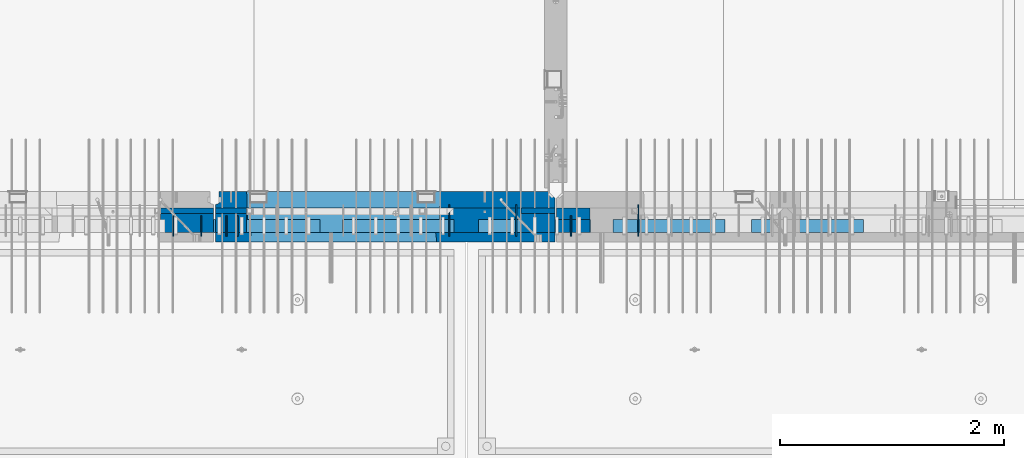
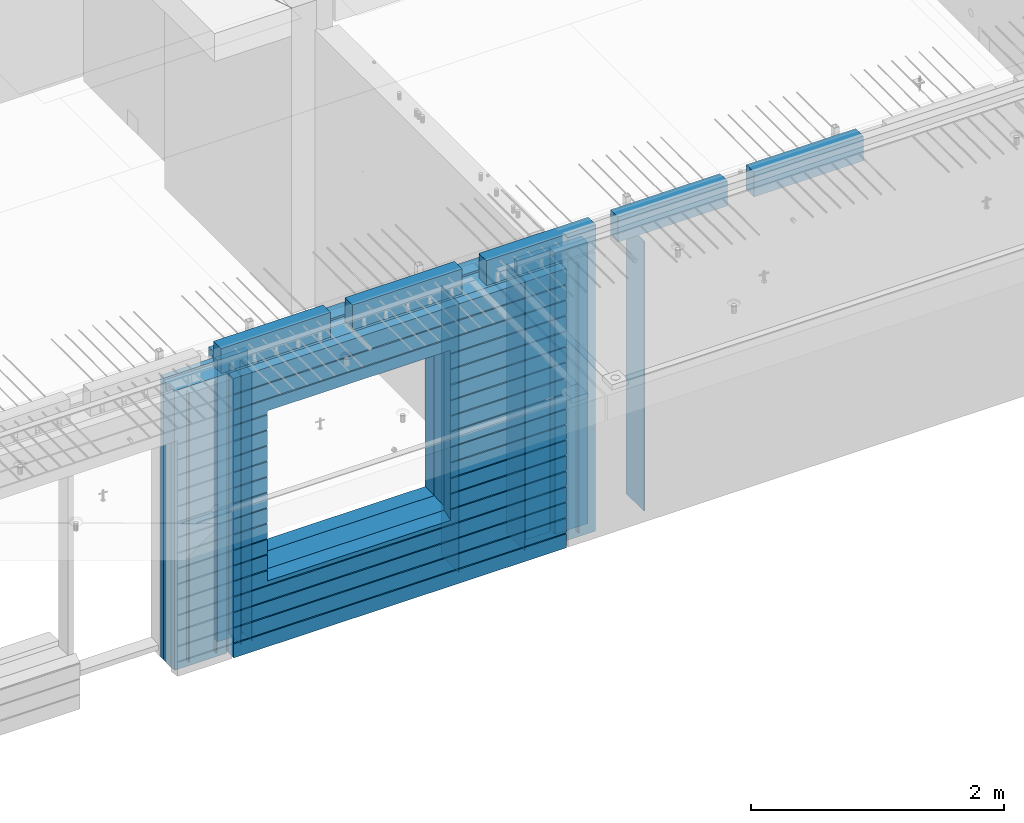
# One storey, part 232 of 349: 24 walls, 10 elements without a shape of their own.
"""IFC2X3 building model written with IfcOpenShell, lengths in millimetres."""

import ifcopenshell
import ifcopenshell.guid

model = None  # the IFC model being written
_history = None  # IfcOwnerHistory: only IFC2X3 demands one
_inside = {}  # id of a spatial element -> (the spatial element, [elements in it])
_under = {}  # id of a project, library or spatial element -> (it, [spatial elements below it])
_declared = {}  # id of a project -> (the project, [libraries it declares])
_typed = {}  # id of a type object -> (the type object, [elements of that type])
_made_of = {}  # id of a material, layer set ... -> (it, [elements and type objects made of it])


def new_model(schema):
    """Start an empty IFC model of exactly this schema.

    Asked for "IFC4X3", IfcOpenShell would pick the latest addendum, in which some entities
    have other attributes; the version numbers below select the first issue.
    IFC2X3 requires an IfcOwnerHistory on every rooted entity: one is made here for all.
    """
    global model, _history
    if schema == "IFC4X3":
        model = ifcopenshell.file(schema_version=(4, 3, 0, 0))
    else:
        model = ifcopenshell.file(schema=schema)
    _inside.clear()
    _under.clear()
    _declared.clear()
    _typed.clear()
    _made_of.clear()
    _history = None
    if model.schema == "IFC2X3":
        org = make("IfcOrganization", Name="unknown")
        user = make(
            "IfcPersonAndOrganization",
            ThePerson=make("IfcPerson", FamilyName="unknown"),
            TheOrganization=org,
        )
        app = make(
            "IfcApplication",
            ApplicationDeveloper=org,
            Version="unknown",
            ApplicationFullName="unknown",
            ApplicationIdentifier="unknown",
        )
        _history = make(
            "IfcOwnerHistory",
            OwningUser=user,
            OwningApplication=app,
            ChangeAction="ADDED",
            CreationDate=0,
        )
    return model


def make(cls, **values):
    """One entity of the class cls with the attributes given. An attribute that is None is left unset."""
    return model.create_entity(
        cls, **{name: value for name, value in values.items() if value is not None}
    )


def rooted(cls, **values):
    """An entity with a GlobalId (a new one), such as an element, a storey or a relation."""
    return make(cls, GlobalId=ifcopenshell.guid.new(), OwnerHistory=_history, **values)


def si_unit(unit_type, name, prefix=None):
    """IfcSIUnit, for example si_unit("LENGTHUNIT", "METRE", prefix="MILLI")."""
    return make("IfcSIUnit", UnitType=unit_type, Prefix=prefix, Name=name)


def assignment(units):
    """IfcUnitAssignment: the units of a project."""
    return None if units is None else make("IfcUnitAssignment", Units=units)


def point(xyz):
    """IfcCartesianPoint."""
    return None if xyz is None else make("IfcCartesianPoint", Coordinates=xyz)


def direction(xyz):
    """IfcDirection."""
    return None if xyz is None else make("IfcDirection", DirectionRatios=xyz)


def frame(location, z_axis=None, x_axis=None):
    """IfcAxis2Placement3D, a coordinate frame: its origin and axes. An axis left out is left unset."""
    return make(
        "IfcAxis2Placement3D",
        Location=point(location),
        Axis=direction(z_axis),
        RefDirection=direction(x_axis),
    )


def origin_with_axes():
    """The frame at (0, 0, 0) with the z axis (0, 0, 1) and the x axis (1, 0, 0) written out."""
    return frame((0.0, 0.0, 0.0), z_axis=(0.0, 0.0, 1.0), x_axis=(1.0, 0.0, 0.0))


def place(relative_to, where):
    """IfcLocalPlacement: puts the frame where relative to a parent placement (None: the world)."""
    return make(
        "IfcLocalPlacement", PlacementRelTo=relative_to, RelativePlacement=where
    )


def context(
    kind, dimensions, precision=None, world=None, true_north=None, identifier=None
):
    """IfcGeometricRepresentationContext, for example the 3D "Model" context."""
    return make(
        "IfcGeometricRepresentationContext",
        ContextIdentifier=identifier,
        ContextType=kind,
        CoordinateSpaceDimension=dimensions,
        Precision=precision,
        WorldCoordinateSystem=world,
        TrueNorth=true_north,
    )


def subcontext(parent, identifier, kind, view, scale=None):
    """IfcGeometricRepresentationSubContext, for example "Body" below "Model"."""
    return make(
        "IfcGeometricRepresentationSubContext",
        ContextIdentifier=identifier,
        ContextType=kind,
        ParentContext=parent,
        TargetScale=scale,
        TargetView=view,
    )


def project(units=None, contexts=None):
    """IfcProject with its units and contexts."""
    return rooted(
        "IfcProject",
        Name="project",
        RepresentationContexts=contexts,
        UnitsInContext=assignment(units),
    )


def spatial(cls, under=None, at=None, **own):
    """A site, building, storey or space (cls), placed at a placement, below another one or the project."""
    s = rooted(cls, ObjectPlacement=at, **own)
    if under is not None:
        _under.setdefault(under.id(), (under, []))[1].append(s)
    return s


def faces_of(points, faces, orient=None, outer=None):
    """IfcFace entities. A face is a list of loops; a loop is a list of indices into points, from 0.

    orient and outer hold one flag for each loop. By default every Orientation is true, the
    first loop of a face is its IfcFaceOuterBound and the others are IfcFaceBound.
    """
    made = []
    for i, loops in enumerate(faces):
        bounds = []
        for j, loop in enumerate(loops):
            is_outer = j == 0 if outer is None else outer[i][j]
            bounds.append(
                make(
                    "IfcFaceOuterBound" if is_outer else "IfcFaceBound",
                    Bound=make("IfcPolyLoop", Polygon=[points[k] for k in loop]),
                    Orientation=True if orient is None else orient[i][j],
                )
            )
        made.append(make("IfcFace", Bounds=bounds))
    return made


def faceted_brep(points, faces, orient=None, outer=None, voids=None):
    """IfcFacetedBrep: a solid bounded by flat faces; with voids (closed shells), ...WithVoids."""
    shared = [point(p) for p in points]
    hull = make("IfcClosedShell", CfsFaces=faces_of(shared, faces, orient, outer))
    if voids is None:
        return make("IfcFacetedBrep", Outer=hull)
    return make(
        "IfcFacetedBrepWithVoids",
        Outer=hull,
        Voids=[
            make(cls, CfsFaces=faces_of(shared, fs, o, b)) for cls, fs, o, b in voids
        ],
    )


def shape(context_of_items, identifier, shape_type, items):
    """IfcShapeRepresentation: the items that make up one representation, for example the "Body"."""
    return make(
        "IfcShapeRepresentation",
        ContextOfItems=context_of_items,
        RepresentationIdentifier=identifier,
        RepresentationType=shape_type,
        Items=items,
    )


def material(Name=None, Category=None):
    """IfcMaterial."""
    return make("IfcMaterial", Name=Name, Category=Category)


def made_of(thing, what):
    """Note that an element or type object is made of a material, layer set ...; save() writes the relation."""
    if what is not None:
        _made_of.setdefault(what.id(), (what, []))[1].append(thing)
    return thing


def type_object(cls, material=None, **own):
    """A type object (cls), such as IfcWallType, which elements share."""
    return made_of(rooted(cls, **own), material)


def element(
    cls,
    number,
    at=None,
    inside=None,
    cuts=None,
    type_object=None,
    material=None,
    context=None,
    identifier="Body",
    shape_type=None,
    held_by="IfcProductDefinitionShape",
    body=None,
    shapes=None,
    **own,
):
    """One element of the class cls, such as IfcWall. Its Tag is "e" and its number.

    at: its placement. inside: the storey or other place that contains it. cuts: it is an
    opening in that element (IfcRelVoidsElement). A single representation is given by context,
    identifier, shape_type and body (its items); several are given by shapes. held_by: the class
    of the entity that holds the representations. save() writes the other relations.
    """
    e = rooted(cls, Tag="e%d" % number, ObjectPlacement=at, **own)
    if body is not None:
        shapes = [shape(context, identifier, shape_type, body)]
    if shapes is not None:
        e.Representation = make(held_by, Representations=shapes)
    if inside is not None:
        _inside.setdefault(inside.id(), (inside, []))[1].append(e)
    if cuts is not None:
        rooted(
            "IfcRelVoidsElement", RelatingBuildingElement=cuts, RelatedOpeningElement=e
        )
    if type_object is not None:
        _typed.setdefault(type_object.id(), (type_object, []))[1].append(e)
    return made_of(e, material)


def aggregate(whole, parts):
    """IfcRelAggregates: a whole, such as a stair, and the parts it consists of."""
    return rooted("IfcRelAggregates", RelatingObject=whole, RelatedObjects=parts)


def save(model, path):
    """Write the relations noted so far, then the file.

    IfcRelAggregates (storeys below a building ...), IfcRelContainedInSpatialStructure (elements
    in a storey), IfcRelDefinesByType, IfcRelAssociatesMaterial and IfcRelDeclares: one each for
    every whole, place, type object, material and project.
    """
    for whole, parts in _under.values():
        aggregate(whole, parts)
    for where, things in _inside.values():
        rooted(
            "IfcRelContainedInSpatialStructure",
            RelatedElements=things,
            RelatingStructure=where,
        )
    for kind, things in _typed.values():
        rooted("IfcRelDefinesByType", RelatedObjects=things, RelatingType=kind)
    for what, things in _made_of.values():
        rooted("IfcRelAssociatesMaterial", RelatedObjects=things, RelatingMaterial=what)
    for by, libraries in _declared.values():
        rooted("IfcRelDeclares", RelatingContext=by, RelatedDefinitions=libraries)
    model.write(path)


model = new_model("IFC2X3")

# Units and contexts
model_context = context("Model", 3, precision=1e-05, world=origin_with_axes())
body_context = subcontext(model_context, "Body", "Model", "MODEL_VIEW")
ifc_project = project(units=[si_unit("LENGTHUNIT", "METRE", prefix="MILLI"), si_unit("AREAUNIT", "SQUARE_METRE"), si_unit("VOLUMEUNIT", "CUBIC_METRE"), si_unit("MASSUNIT", "GRAM", prefix="KILO"), si_unit("TIMEUNIT", "SECOND"), si_unit("PLANEANGLEUNIT", "RADIAN"), si_unit("SOLIDANGLEUNIT", "STERADIAN"), si_unit("THERMODYNAMICTEMPERATUREUNIT", "DEGREE_CELSIUS"), si_unit("LUMINOUSINTENSITYUNIT", "LUMEN")], contexts=[model_context])

# Site, building, storey
site_placement = place(None, origin_with_axes())
site = spatial("IfcSite", under=ifc_project, at=site_placement, CompositionType="ELEMENT")
building_placement = place(site_placement, origin_with_axes())
building = spatial("IfcBuilding", under=site, at=building_placement, CompositionType="ELEMENT")
storey_placement = place(building_placement, origin_with_axes())
storey = spatial("IfcBuildingStorey", under=building, at=storey_placement, Name="4", CompositionType="ELEMENT", Elevation=0.0)

# Assembly, walls
assembly_1_placement = place(storey_placement, origin_with_axes())
assembly_1 = element("IfcElementAssembly", 1, at=assembly_1_placement, inside=storey, AssemblyPlace="NOTDEFINED", PredefinedType="REINFORCEMENT_UNIT")
ifc_material_1 = material(Name="Undefined")
wall_type_1 = type_object("IfcWallType", PredefinedType="NOTDEFINED")
wall_1_placement = place(assembly_1_placement, frame((25665.0, 7780.0, 92115.0), z_axis=(0.0, 0.0, 1.0), x_axis=(0.0, -1.0, 0.0)))
wall_1 = element("IfcWall", 2, at=wall_1_placement, type_object=wall_type_1, material=ifc_material_1, Name="(PD)", context=body_context, shape_type="Brep", body=[
    faceted_brep([(0.0, 5.0, -1300.0), (0.0, 5.0, 1300.0), (180.0, 5.0, 1300.0), (180.0, 5.0, -1300.0), (0.0, -5.0, 1300.0), (180.0, -5.0, 1300.0), (0.0, -5.0, -1300.0), (180.0, -5.0, -1300.0)], [[[0, 1, 2, 3]], [[1, 4, 5, 2]], [[4, 6, 7, 5]], [[6, 0, 3, 7]], [[5, 7, 3, 2]], [[6, 4, 1, 0]]]),
])
wall_2_placement = place(assembly_1_placement, frame((25765.0, 7780.0, 92115.0), z_axis=(0.0, 0.0, 1.0), x_axis=(0.0, -1.0, 0.0)))
wall_2 = element("IfcWall", 3, at=wall_2_placement, type_object=wall_type_1, material=ifc_material_1, Name="(PD)", context=body_context, shape_type="Brep", body=[
    faceted_brep([(0.0, 5.0, -1300.0), (0.0, 5.0, 1300.0), (180.0, 5.0, 1300.0), (180.0, 5.0, -1300.0), (0.0, -5.0, 1300.0), (180.0, -5.0, 1300.0), (0.0, -5.0, -1300.0), (180.0, -5.0, -1300.0)], [[[0, 1, 2, 3]], [[1, 4, 5, 2]], [[4, 6, 7, 5]], [[6, 0, 3, 7]], [[5, 7, 3, 2]], [[6, 4, 1, 0]]]),
])
wall_3_placement = place(assembly_1_placement, frame((28255.0, 7880.0, 92115.0), z_axis=(0.0, 0.0, 1.0), x_axis=(0.0, -1.0, 0.0)))
wall_3 = element("IfcWall", 4, at=wall_3_placement, type_object=wall_type_1, material=ifc_material_1, Name="(PD)", context=body_context, shape_type="Brep", body=[
    faceted_brep([(0.0, 5.0, -1300.0), (0.0, 5.0, 1300.0), (280.0, 5.0, 1300.0), (280.0, 5.0, -1300.0), (0.0, -5.0, 1300.0), (280.0, -5.0, 1300.0), (0.0, -5.0, -1300.0), (280.0, -5.0, -1300.0)], [[[0, 1, 2, 3]], [[1, 4, 5, 2]], [[4, 6, 7, 5]], [[6, 0, 3, 7]], [[5, 7, 3, 2]], [[6, 4, 1, 0]]]),
])

assembly_2_placement = place(storey_placement, origin_with_axes())
assembly_2 = element("IfcElementAssembly", 5, at=assembly_2_placement, inside=storey, AssemblyPlace="NOTDEFINED", PredefinedType="REINFORCEMENT_UNIT")
wall_4_placement = place(assembly_2_placement, frame((28745.0021834468, 7780.0, 92115.0), z_axis=(0.0, 0.0, 1.0), x_axis=(0.0, -1.0, 0.0)))
wall_4 = element("IfcWall", 6, at=wall_4_placement, type_object=wall_type_1, material=ifc_material_1, Name="(PD)", context=body_context, shape_type="Brep", body=[
    faceted_brep([(0.0, 5.0, -1300.0), (0.0, 5.0, 1300.0), (180.0, 5.0, 1300.0), (180.0, 5.0, -1300.0), (0.0, -5.0, 1300.0), (180.0, -5.0, 1300.0), (0.0, -5.0, -1300.0), (180.0, -5.0, -1300.0)], [[[0, 1, 2, 3]], [[1, 4, 5, 2]], [[4, 6, 7, 5]], [[6, 0, 3, 7]], [[5, 7, 3, 2]], [[6, 4, 1, 0]]]),
])
wall_5_placement = place(assembly_2_placement, frame((29345.0021834468, 7880.0, 92115.0), z_axis=(0.0, 0.0, 1.0), x_axis=(0.0, -1.0, 0.0)))
wall_5 = element("IfcWall", 7, at=wall_5_placement, type_object=wall_type_1, material=ifc_material_1, Name="(PD)", context=body_context, shape_type="Brep", body=[
    faceted_brep([(0.0, 5.0, -1300.0), (0.0, 5.0, 1300.0), (280.0, 5.0, 1300.0), (280.0, 5.0, -1300.0), (0.0, -5.0, 1300.0), (280.0, -5.0, 1300.0), (0.0, -5.0, -1300.0), (280.0, -5.0, -1300.0)], [[[0, 1, 2, 3]], [[1, 4, 5, 2]], [[4, 6, 7, 5]], [[6, 0, 3, 7]], [[5, 7, 3, 2]], [[6, 4, 1, 0]]]),
])

assembly_3_placement = place(storey_placement, origin_with_axes())
assembly_3 = element("IfcElementAssembly", 8, at=assembly_3_placement, inside=storey, AssemblyPlace="NOTDEFINED", PredefinedType="REINFORCEMENT_UNIT")
wall_6_placement = place(assembly_3_placement, frame((25190.0, 7780.0, 92115.0), z_axis=(0.0, 0.0, 1.0), x_axis=(0.0, -1.0, 0.0)))
wall_6 = element("IfcWall", 9, at=wall_6_placement, type_object=wall_type_1, material=ifc_material_1, Name="(PD)", context=body_context, shape_type="Brep", body=[
    faceted_brep([(0.0, 5.0, -1300.0), (0.0, 5.0, 1300.0), (180.0, 5.0, 1300.0), (180.0, 5.0, -1300.0), (0.0, -5.0, 1300.0), (180.0, -5.0, 1300.0), (0.0, -5.0, -1300.0), (180.0, -5.0, -1300.0)], [[[0, 1, 2, 3]], [[1, 4, 5, 2]], [[4, 6, 7, 5]], [[6, 0, 3, 7]], [[5, 7, 3, 2]], [[6, 4, 1, 0]]]),
])
wall_7_placement = place(assembly_3_placement, frame((25440.0, 7780.0, 92115.0), z_axis=(0.0, 0.0, 1.0), x_axis=(0.0, -1.0, 0.0)))
wall_7 = element("IfcWall", 10, at=wall_7_placement, type_object=wall_type_1, material=ifc_material_1, Name="(PD)", context=body_context, shape_type="Brep", body=[
    faceted_brep([(0.0, 5.0, -1300.0), (0.0, 5.0, 1300.0), (180.0, 5.0, 1300.0), (180.0, 5.0, -1300.0), (0.0, -5.0, 1300.0), (180.0, -5.0, 1300.0), (0.0, -5.0, -1300.0), (180.0, -5.0, -1300.0)], [[[0, 1, 2, 3]], [[1, 4, 5, 2]], [[4, 6, 7, 5]], [[6, 0, 3, 7]], [[5, 7, 3, 2]], [[6, 4, 1, 0]]]),
])

# Wall
wall_8_placement = place(assembly_1_placement, frame((27655.0, 7880.0, 92115.0), z_axis=(0.0, 0.0, 1.0), x_axis=(0.0, -1.0, 0.0)))
wall_8 = element("IfcWall", 11, at=wall_8_placement, type_object=wall_type_1, material=ifc_material_1, Name="(PD)", context=body_context, shape_type="Brep", body=[
    faceted_brep([(0.0, 5.0, -1300.0), (0.0, 5.0, 1300.0), (280.0, 5.0, 1300.0), (280.0, 5.0, -1300.0), (0.0, -5.0, 1300.0), (280.0, -5.0, 1300.0), (0.0, -5.0, -1300.0), (280.0, -5.0, -1300.0)], [[[0, 1, 2, 3]], [[1, 4, 5, 2]], [[4, 6, 7, 5]], [[6, 0, 3, 7]], [[5, 7, 3, 2]], [[6, 4, 1, 0]]]),
])

# Assemblies, walls
assembly_4_placement = place(storey_placement, origin_with_axes())
assembly_4 = element("IfcElementAssembly", 12, at=assembly_4_placement, inside=storey, AssemblyPlace="NOTDEFINED", PredefinedType="REINFORCEMENT_UNIT")
assembly_5_placement = place(assembly_4_placement, origin_with_axes())
assembly_5 = element("IfcElementAssembly", 13, at=assembly_5_placement, Name="Steel Assembly", AssemblyPlace="NOTDEFINED", PredefinedType="NOTDEFINED")
ifc_material_2 = material()
wall_type_2 = type_object("IfcWallType", PredefinedType="NOTDEFINED")
wall_9_placement = place(assembly_5_placement, frame((26699.9998568133, 7690.00021946163, 93590.0), z_axis=(0.0, 0.0, 1.0), x_axis=(1.0, 0.0, 0.0)))
wall_9 = element("IfcWall", 14, at=wall_9_placement, type_object=wall_type_2, material=ifc_material_2, context=body_context, shape_type="Brep", body=[
    faceted_brep([(0.0, 60.0, -120.0), (0.0, 60.0, 120.0), (1000.0, 60.0, 120.0), (1000.0, 60.0, -120.0), (0.0, -60.0, 120.0), (1000.0, -60.0, 120.0), (0.0, -60.0, -120.0), (1000.0, -60.0, -120.0)], [[[0, 1, 2, 3]], [[1, 4, 5, 2]], [[4, 6, 7, 5]], [[6, 0, 3, 7]], [[5, 7, 3, 2]], [[6, 4, 1, 0]]]),
])
aggregate(assembly_5, [wall_9])
assembly_6_placement = place(assembly_4_placement, origin_with_axes())
assembly_6 = element("IfcElementAssembly", 15, at=assembly_6_placement, Name="Steel Assembly", AssemblyPlace="NOTDEFINED", PredefinedType="NOTDEFINED")
aggregate(assembly_4, [assembly_6, assembly_5])
wall_10_placement = place(assembly_6_placement, frame((25499.9998568133, 7690.00021946163, 93590.0), z_axis=(0.0, 0.0, 1.0), x_axis=(1.0, 0.0, 0.0)))
wall_10 = element("IfcWall", 16, at=wall_10_placement, type_object=wall_type_2, material=ifc_material_2, context=body_context, shape_type="Brep", body=[
    faceted_brep([(0.0, 60.0, -120.0), (0.0, 60.0, 120.0), (1000.0, 60.0, 120.0), (1000.0, 60.0, -120.0), (0.0, -60.0, 120.0), (1000.0, -60.0, 120.0), (0.0, -60.0, -120.0), (1000.0, -60.0, -120.0)], [[[0, 1, 2, 3]], [[1, 4, 5, 2]], [[4, 6, 7, 5]], [[6, 0, 3, 7]], [[5, 7, 3, 2]], [[6, 4, 1, 0]]]),
])
aggregate(assembly_6, [wall_10])

assembly_7_placement = place(storey_placement, origin_with_axes())
assembly_7 = element("IfcElementAssembly", 17, at=assembly_7_placement, inside=storey, AssemblyPlace="NOTDEFINED", PredefinedType="REINFORCEMENT_UNIT")
assembly_8_placement = place(assembly_7_placement, origin_with_axes())
assembly_8 = element("IfcElementAssembly", 18, at=assembly_8_placement, Name="Steel Assembly", AssemblyPlace="NOTDEFINED", PredefinedType="NOTDEFINED")
wall_11_placement = place(assembly_8_placement, frame((30359.9998568133, 7690.00021946163, 93590.0), z_axis=(0.0, 0.0, 1.0), x_axis=(1.0, 0.0, 0.0)))
wall_11 = element("IfcWall", 19, at=wall_11_placement, type_object=wall_type_2, material=ifc_material_2, context=body_context, shape_type="Brep", body=[
    faceted_brep([(0.0, 60.0, -120.0), (0.0, 60.0, 120.0), (1000.0, 60.0, 120.0), (1000.0, 60.0, -120.0), (0.0, -60.0, 120.0), (1000.0, -60.0, 120.0), (0.0, -60.0, -120.0), (1000.0, -60.0, -120.0)], [[[0, 1, 2, 3]], [[1, 4, 5, 2]], [[4, 6, 7, 5]], [[6, 0, 3, 7]], [[5, 7, 3, 2]], [[6, 4, 1, 0]]]),
])
aggregate(assembly_8, [wall_11])
assembly_9_placement = place(assembly_7_placement, origin_with_axes())
assembly_9 = element("IfcElementAssembly", 20, at=assembly_9_placement, Name="Steel Assembly", AssemblyPlace="NOTDEFINED", PredefinedType="NOTDEFINED")
wall_12_placement = place(assembly_9_placement, frame((29119.9998568133, 7690.00021946163, 93590.0), z_axis=(0.0, 0.0, 1.0), x_axis=(1.0, 0.0, 0.0)))
wall_12 = element("IfcWall", 21, at=wall_12_placement, type_object=wall_type_2, material=ifc_material_2, context=body_context, shape_type="Brep", body=[
    faceted_brep([(0.0, 60.0, -120.0), (0.0, 60.0, 120.0), (1000.0, 60.0, 120.0), (1000.0, 60.0, -120.0), (0.0, -60.0, 120.0), (1000.0, -60.0, 120.0), (0.0, -60.0, -120.0), (1000.0, -60.0, -120.0)], [[[0, 1, 2, 3]], [[1, 4, 5, 2]], [[4, 6, 7, 5]], [[6, 0, 3, 7]], [[5, 7, 3, 2]], [[6, 4, 1, 0]]]),
])
aggregate(assembly_9, [wall_12])
assembly_10_placement = place(assembly_7_placement, origin_with_axes())
assembly_10 = element("IfcElementAssembly", 22, at=assembly_10_placement, Name="Steel Assembly", AssemblyPlace="NOTDEFINED", PredefinedType="NOTDEFINED")
aggregate(assembly_7, [assembly_10, assembly_9, assembly_8])
wall_13_placement = place(assembly_10_placement, frame((27919.9998568133, 7690.00021946163, 93590.0), z_axis=(0.0, 0.0, 1.0), x_axis=(1.0, 0.0, 0.0)))
wall_13 = element("IfcWall", 23, at=wall_13_placement, type_object=wall_type_2, material=ifc_material_2, context=body_context, shape_type="Brep", body=[
    faceted_brep([(0.0, 60.0, -120.0), (0.0, 60.0, 120.0), (1000.0, 60.0, 120.0), (1000.0, 60.0, -120.0), (0.0, -60.0, 120.0), (1000.0, -60.0, 120.0), (0.0, -60.0, -120.0), (1000.0, -60.0, -120.0)], [[[0, 1, 2, 3]], [[1, 4, 5, 2]], [[4, 6, 7, 5]], [[6, 0, 3, 7]], [[5, 7, 3, 2]], [[6, 4, 1, 0]]]),
])
aggregate(assembly_10, [wall_13])

# Wall
ifc_material_3 = material(Name="CONCRETE/C35/45")
wall_type_3 = type_object("IfcWallType", PredefinedType="NOTDEFINED")
wall_14_placement = place(assembly_1_placement, frame((28600.0, 7925.0, 92112.5), z_axis=(0.0, 0.0, 1.0), x_axis=(-1.0, 3.00000001838171e-08, 0.0)))
wall_14 = element("IfcWall", 24, at=wall_14_placement, type_object=wall_type_3, material=ifc_material_3, context=body_context, shape_type="Brep", body=[
    faceted_brep([(0.0, 75.0, 1357.5), (0.0, 75.0, -1357.5), (0.0, -15.0, -1357.5), (0.0, -15.0, 1357.5), (60.0, -75.0, -1357.5), (3035.00000000003, 75.0, -1357.5), (3035.00000000003, 45.0, -1357.5), (3002.5, 32.0, -1357.5), (3002.5, -75.0, -1357.5), (60.0, -75.0, 1357.5), (3035.00000000003, 45.0, 1357.5), (3035.00000000003, 75.0, 1357.5), (3002.5, -75.0, 1357.5), (3002.5, 32.0, 1357.5), (2755.00051719707, -75.0, -682.5), (1025.00051719707, -75.0, -682.5), (1025.00051719707, -75.0, 952.5), (2755.00051719707, -75.0, 952.5), (2750.94646314301, 75.0, -678.445945945947), (1029.05457125112, 75.0, -678.445945945947), (1029.05457125112, 75.0, 948.445945945947), (2750.94646314301, 75.0, 948.445945945947)], [[[0, 1, 2, 3]], [[4, 2, 1, 5, 6, 7, 8]], [[3, 2, 4, 9]], [[10, 11, 0, 3, 9, 12, 13]], [[5, 11, 10, 6]], [[13, 7, 6, 10]], [[12, 8, 7, 13]], [[9, 4, 8, 12], [14, 15, 16, 17]], [[14, 18, 19, 15]], [[15, 19, 20, 16]], [[1, 0, 11, 5], [18, 21, 20, 19]], [[16, 20, 21, 17]], [[18, 14, 17, 21]]]),
])

wall_type_4 = type_object("IfcWallType", PredefinedType="NOTDEFINED")
wall_15_placement = place(assembly_2_placement, frame((28915.0000381475, 7800.0, 92112.5), z_axis=(0.0, 0.0, 1.0), x_axis=(-1.0, 3.00000001838171e-08, 0.0)))
wall_15 = element("IfcWall", 25, at=wall_15_placement, type_object=wall_type_4, material=ifc_material_3, context=body_context, shape_type="Brep", body=[
    faceted_brep([(0.0, 50.0, -1357.5), (0.0, 50.0, 1357.5), (300.001908754726, 50.0, 1357.5), (300.001908754726, 50.0, -1357.5), (0.0, -50.0, 1357.5), (300.001908754726, -50.0, 1357.5), (0.0, -50.0, -1357.5), (300.001908754726, -50.0, -1357.5)], [[[0, 1, 2, 3]], [[1, 4, 5, 2]], [[4, 6, 7, 5]], [[6, 0, 3, 7]], [[5, 7, 3, 2]], [[6, 4, 1, 0]]]),
])

ifc_material_4 = material(Name="SPU")
wall_type_5 = type_object("IfcWallType", PredefinedType="NOTDEFINED")
wall_16_placement = place(assembly_2_placement, frame((28915.0000381475, 7690.0, 92102.5), z_axis=(0.0, 0.0, 1.0), x_axis=(-1.0, 3.00000001838171e-08, 0.0)))
wall_16 = element("IfcWall", 26, at=wall_16_placement, type_object=wall_type_5, material=ifc_material_4, context=body_context, shape_type="Brep", body=[
    faceted_brep([(0.0, 60.0, -1347.5), (0.0, 60.0, 1347.5), (300.001908754726, 60.0, 1347.5), (300.001908754726, 60.0, -1347.5), (0.0, -60.0, 1347.5), (300.001908754726, -60.0, 1347.5), (0.0, -60.0, -1347.5), (300.001908754726, -60.0, -1347.5)], [[[0, 1, 2, 3]], [[1, 4, 5, 2]], [[4, 6, 7, 5]], [[6, 0, 3, 7]], [[5, 7, 3, 2]], [[6, 4, 1, 0]]]),
])

aggregate(assembly_2, [wall_16, wall_15, wall_4, wall_5])

wall_type_6 = type_object("IfcWallType", PredefinedType="NOTDEFINED")
wall_17_placement = place(assembly_1_placement, frame((28600.0000381475, 7825.0, 92112.5), z_axis=(0.0, 0.0, 1.0), x_axis=(-1.0, 3.00000001838171e-08, 0.0)))
wall_17 = element("IfcWall", 27, at=wall_17_placement, type_object=wall_type_6, material=ifc_material_3, context=body_context, shape_type="Brep", body=[
    faceted_brep([(0.0, 25.0, -1357.5), (0.0, 25.0, 1357.5), (300.001908754726, 25.0, 1357.5), (300.001908754726, 25.0, -1357.5), (0.0, -25.0, 1357.5), (300.001908754726, -25.0, 1357.5), (0.0, -25.0, -1357.5), (300.001908754726, -25.0, -1357.5)], [[[0, 1, 2, 3]], [[1, 4, 5, 2]], [[4, 6, 7, 5]], [[6, 0, 3, 7]], [[5, 7, 3, 2]], [[6, 4, 1, 0]]]),
])

wall_18_placement = place(assembly_3_placement, frame((25550.0000381475, 7825.00011629906, 92112.5), z_axis=(0.0, 0.0, 1.0), x_axis=(-1.0, 3.00000001838171e-08, 0.0)))
wall_18 = element("IfcWall", 28, at=wall_18_placement, type_object=wall_type_6, material=ifc_material_3, context=body_context, shape_type="Brep", body=[
    faceted_brep([(0.0, 25.0, -1357.5), (0.0, 25.0, 1357.5), (475.001908754726, 25.0, 1357.5), (475.001908754726, 25.0, -1357.5), (0.0, -25.0, 1357.5), (475.001908754726, -25.0, 1357.5), (0.0, -25.0, -1357.5), (475.001908754726, -25.0, -1357.5)], [[[0, 1, 2, 3]], [[1, 4, 5, 2]], [[4, 6, 7, 5]], [[6, 0, 3, 7]], [[5, 7, 3, 2]], [[6, 4, 1, 0]]]),
])

wall_19_placement = place(assembly_1_placement, frame((25845.0000381475, 7825.0, 92112.5), z_axis=(0.0, 0.0, 1.0), x_axis=(-1.0, 3.00000001838171e-08, 0.0)))
wall_19 = element("IfcWall", 29, at=wall_19_placement, type_object=wall_type_6, material=ifc_material_3, context=body_context, shape_type="Brep", body=[
    faceted_brep([(0.0, 25.0, -1357.5), (0.0, 25.0, 1357.5), (280.001908754726, 25.0, 1357.5), (280.001908754726, 25.0, -1357.5), (0.0, -25.0, 1357.5), (280.001908754726, -25.0, 1357.5), (0.0, -25.0, -1357.5), (280.001908754726, -25.0, -1357.5)], [[[0, 1, 2, 3]], [[1, 4, 5, 2]], [[4, 6, 7, 5]], [[6, 0, 3, 7]], [[5, 7, 3, 2]], [[6, 4, 1, 0]]]),
])

wall_type_7 = type_object("IfcWallType", PredefinedType="NOTDEFINED")
wall_20_placement = place(assembly_3_placement, frame((25550.0000381475, 7715.00011629906, 92102.5), z_axis=(0.0, 0.0, 1.0), x_axis=(-1.0, 3.00000001838171e-08, 0.0)))
wall_20 = element("IfcWall", 30, at=wall_20_placement, type_object=wall_type_7, material=ifc_material_4, context=body_context, shape_type="Brep", body=[
    faceted_brep([(0.0, 85.0, -1347.5), (0.0, 85.0, 1347.5), (475.001908754726, 85.0, 1347.5), (475.001908754726, 85.0, -1347.5), (0.0, -85.0, 1347.5), (475.001908754726, -85.0, 1347.5), (0.0, -85.0, -1347.5), (475.001908754726, -85.0, -1347.5)], [[[0, 1, 2, 3]], [[1, 4, 5, 2]], [[4, 6, 7, 5]], [[6, 0, 3, 7]], [[5, 7, 3, 2]], [[6, 4, 1, 0]]]),
])

aggregate(assembly_3, [wall_20, wall_18, wall_6, wall_7])

wall_21_placement = place(assembly_1_placement, frame((28600.0000381475, 7715.0, 92102.5), z_axis=(0.0, 0.0, 1.0), x_axis=(-1.0, 3.00000001838171e-08, 0.0)))
wall_21 = element("IfcWall", 31, at=wall_21_placement, type_object=wall_type_7, material=ifc_material_4, context=body_context, shape_type="Brep", body=[
    faceted_brep([(0.0, 85.0, -1347.5), (0.0, 85.0, 1347.5), (300.001908754726, 85.0, 1347.5), (300.001908754726, 85.0, -1347.5), (0.0, -85.0, 1347.5), (300.001908754726, -85.0, 1347.5), (0.0, -85.0, -1347.5), (300.001908754726, -85.0, -1347.5)], [[[0, 1, 2, 3]], [[1, 4, 5, 2]], [[4, 6, 7, 5]], [[6, 0, 3, 7]], [[5, 7, 3, 2]], [[6, 4, 1, 0]]]),
])

wall_22_placement = place(assembly_1_placement, frame((25845.0000381475, 7715.0, 92102.5), z_axis=(0.0, 0.0, 1.0), x_axis=(-1.0, 3.00000001838171e-08, 0.0)))
wall_22 = element("IfcWall", 32, at=wall_22_placement, type_object=wall_type_7, material=ifc_material_4, context=body_context, shape_type="Brep", body=[
    faceted_brep([(0.0, 85.0, -1347.5), (0.0, 85.0, 1347.5), (280.001908754726, 85.0, 1347.5), (280.001908754726, 85.0, -1347.5), (0.0, -85.0, 1347.5), (280.001908754726, -85.0, 1347.5), (0.0, -85.0, -1347.5), (280.001908754726, -85.0, -1347.5)], [[[0, 1, 2, 3]], [[1, 4, 5, 2]], [[4, 6, 7, 5]], [[6, 0, 3, 7]], [[5, 7, 3, 2]], [[6, 4, 1, 0]]]),
])

ifc_material_5 = material(Name="CONCRETE/C30/37")
wall_type_8 = type_object("IfcWallType", PredefinedType="NOTDEFINED")
wall_23_placement = place(assembly_1_placement, frame((28600.0, 7587.5, 92102.5), z_axis=(0.0, 0.0, 1.0), x_axis=(-1.0, 3.00000001838171e-08, 0.0)))
wall_23 = element("IfcWall", 33, at=wall_23_placement, type_object=wall_type_8, material=ifc_material_5, context=body_context, shape_type="Brep", body=[
    faceted_brep([(3.63797880709171e-12, 32.4999991119639, 1050.00000040043), (3035.0, 32.4999991119785, 1050.00000040044), (3035.0, 32.4999992499725, 1039.99999999921), (3.63797880709171e-12, 32.4999992499725, 1039.99999999921), (0.0, 42.5, 1051.99999988925), (3035.0, 42.5, 1051.99999988925), (0.0, 42.5, 1187.99999994476), (3035.0, 42.5, 1187.99999994476), (-3.63797880709171e-12, 32.499999249967, 1189.99999999923), (3035.0, 32.4999992499634, 1189.99999999921), (-3.63797880709171e-12, 32.4999991119576, 1200.00000040043), (3035.0, 32.4999991119703, 1200.00000040044), (0.0, 42.5, 1201.99999988925), (3035.0, 42.5, 1201.99999988925), (0.0, 42.5, 1347.5), (3035.0, 42.5, 1347.5), (0.0, -42.5, 1347.5), (3035.0, -42.5, 1347.5), (0.0, -42.5, -1347.5), (0.0, 42.5, -1347.5), (3035.0, 42.5, -1347.5), (3035.0, -42.5, -1347.5), (0.0, 42.5, -1212.00000005524), (3035.0, 42.5, -1212.00000005524), (0.0, 32.4999992501671, -1210.00000000079), (3035.0, 32.4999992501644, -1210.0000000008), (0.0, 32.4999991121604, -1199.99999959957), (3035.0, 32.4999991121604, -1199.99999959957), (0.0, 42.5, -1198.00000011075), (3035.0, 42.5, -1198.00000011075), (0.0, 42.5, -1062.00000005522), (3035.0, 42.5, -1062.00000005522), (0.0, 32.4999992506973, -1060.00000000076), (3035.0, 32.4999992506928, -1060.00000000079), (0.0, 32.4999991126861, -1049.99999959956), (3035.0, 32.4999991126924, -1049.99999959956), (0.0, 42.5, -1048.00000011074), (3035.0, 42.5, -1048.00000011074), (0.0, 42.5, -912.000000055254), (3035.0, 42.5, -912.000000055254), (0.0, 32.4999992512376, -910.000000000786), (3035.0, 32.4999992512339, -910.000000000815), (0.0, 32.499999113239, -899.99999959959), (3035.0, 32.4999991132327, -899.99999959959), (0.0, 42.5, -898.000000110769), (3035.0, 42.5, -898.000000110769), (0.0, 42.5, -762.000000055225), (3035.0, 42.5, -762.000000055225), (0.0, 32.4999992517696, -760.000000000757), (3035.0, 32.499999251766, -760.000000000786), (0.0, 32.4999991137702, -749.99999959956), (3035.0, 32.4999991137656, -749.99999959956), (0.0, 42.5, -748.00000011074), (3035.0, 42.5, -748.00000011074), (3035.0, 42.5, 901.999999889245), (3035.0, 32.4999991119894, 900.00000040044), (2723.82404650436, 32.4999991119894, 900.00000040044), (2725.00051719707, 42.5, 901.999999889245), (3035.0, 32.4999992499834, 889.999999999214), (2723.82404652059, 32.4999992499834, 889.999999999214), (3035.0, 42.5, 887.999999944761), (2725.00051719707, 42.5, 887.999999944761), (3035.0, 42.5, 751.999999889245), (2725.00051719707, 42.5, 751.999999889245), (3035.0, 32.4999991119967, 750.000000400425), (2723.82404650436, 32.4999991119967, 750.000000400425), (3035.0, 32.4999992499961, 739.9999999992), (2723.82404652059, 32.4999992499961, 739.9999999992), (3035.0, 42.5, 737.999999944761), (2725.00051719707, 42.5, 737.999999944761), (3035.0, 42.5, 601.99999988926), (2725.00051719707, 42.5, 601.99999988926), (3035.0, 32.4999991120212, 600.000000400454), (2723.82404650436, 32.4999991120212, 600.000000400454), (3035.0, 32.4999992500161, 589.999999999229), (2723.8240465206, 32.4999992500161, 589.999999999229), (3035.0, 42.5, 587.999999944775), (2725.00051719707, 42.5, 587.999999944775), (3035.0, 42.5, 451.999999889231), (2725.00051719707, 42.5, 451.999999889231), (3035.0, 32.4999991120285, 450.000000400425), (2723.82404650436, 32.4999991120285, 450.000000400425), (3035.0, 32.4999992500234, 439.9999999992), (2723.8240465206, 32.4999992500234, 439.9999999992), (3035.0, 42.5, 437.999999944746), (2725.00051719707, 42.5, 437.999999944746), (3035.0, 42.5, 301.999999889245), (2725.00051719707, 42.5, 301.999999889245), (3035.0, 32.4999991120458, 300.00000040044), (2723.82404650437, 32.4999991120458, 300.00000040044), (3035.0, 32.4999992500389, 289.999999999214), (2723.8240465206, 32.4999992500389, 289.999999999214), (3035.0, 42.5, 287.999999944761), (2725.00051719707, 42.5, 287.999999944761), (3035.0, 42.5, 151.99999988926), (2725.00051719707, 42.5, 151.99999988926), (3035.0, 32.4999991120585, 150.000000400454), (2723.82404650437, 32.4999991120585, 150.000000400454), (3035.0, 32.4999992500534, 139.999999999229), (2723.8240465206, 32.4999992500534, 139.999999999229), (3035.0, 42.5, 137.999999944775), (2725.00051719707, 42.5, 137.999999944775), (3035.0, 42.5, 1.99999988924537), (2725.00051719707, 42.5, 1.99999988924537), (3035.0, 32.4999992522926, -610.0000000008), (3035.0, 42.5, -612.000000055239), (2725.00051719707, 42.5, -612.000000055239), (2723.82404652087, 32.4999992522926, -610.0000000008), (3035.0, 32.4999991142904, -599.999999599575), (2723.82404650463, 32.4999991142904, -599.999999599575), (3035.0, 42.5, -598.000000110755), (2725.00051719707, 42.5, -598.000000110755), (3035.0, 42.5, -462.000000055239), (2725.00051719707, 42.5, -462.000000055239), (3035.0, 32.4999992528319, -460.0000000008), (2723.82404652093, 32.4999992528319, -460.0000000008), (3035.0, 32.4999991148297, -449.999999599575), (2723.82404650469, 32.4999991148297, -449.999999599575), (3035.0, 42.5, -448.000000110755), (2725.00051719707, 42.5, -448.000000110755), (3035.0, 42.5, -312.000000055254), (2725.00051719707, 42.5, -312.000000055254), (3035.0, 32.4999992533585, -310.000000000815), (2723.82404652099, 32.4999992533585, -310.000000000815), (3035.0, 32.4999991153563, -299.99999959959), (2723.82404650475, 32.4999991153563, -299.99999959959), (3035.0, 42.5, -298.000000110769), (2725.00051719707, 42.5, -298.000000110769), (3035.0, 42.5, -162.000000055239), (2725.00051719707, 42.499999923677, -162.000000055239), (3035.0, 32.4999992538951, -160.0000000008), (2723.82404652105, 32.4999992538951, -160.0000000008), (3035.0, 32.4999991158938, -149.999999599575), (2723.82404650482, 32.4999991158938, -149.999999599575), (3035.0, 42.5, -148.000000110755), (2725.00051719707, 42.4999999210722, -148.000000110755), (3035.0, 42.5, -12.0000000552391), (2725.00051719707, 42.5, -12.0000000552391), (3035.0, 32.4999992538906, -10.0000000008004), (2723.82404652105, 32.4999992538906, -10.0000000008004), (3035.0, 32.4999991158902, 4.00425051338971e-07), (2723.82404650482, 32.4999991158902, 4.00425051338971e-07), (3035.0, 42.5, 1037.99999994476), (0.0, 42.5, 1037.99999994476), (3.63797880709171e-12, 32.4999992499852, 889.999999999229), (3.63797880709171e-12, 32.4999991119857, 900.000000400425), (1056.17698788978, 32.4999991119894, 900.00000040044), (1056.17698787354, 32.4999992499834, 889.999999999214), (0.0, 42.5, 887.999999944761), (1055.00051719707, 42.5, 887.999999944761), (0.0, 42.5, 751.999999889245), (1055.00051719707, 42.5, 751.999999889245), (0.0, 32.4999991120039, 750.00000040044), (1056.17698788978, 32.4999991119967, 750.000000400425), (0.0, 32.4999992499997, 739.999999999229), (1056.17698787354, 32.4999992499961, 739.9999999992), (0.0, 42.5, 737.999999944761), (1055.00051719707, 42.5, 737.999999944761), (0.0, 42.5, 601.99999988926), (1055.00051719707, 42.5, 601.99999988926), (0.0, 32.4999991120094, 600.00000040044), (1056.17698788977, 32.4999991120212, 600.000000400454), (0.0, 32.499999250017, 589.999999999229), (1056.17698787354, 32.4999992500161, 589.999999999229), (0.0, 42.5, 587.999999944775), (1055.00051719707, 42.5, 587.999999944775), (0.0, 42.5, 451.999999889231), (1055.00051719707, 42.5, 451.999999889231), (0.0, 32.4999991120258, 450.000000400411), (1056.17698788977, 32.4999991120285, 450.000000400425), (0.0, 32.4999992500289, 439.999999999214), (1056.17698787354, 32.4999992500234, 439.9999999992), (0.0, 42.5, 437.999999944746), (1055.00051719707, 42.5, 437.999999944746), (0.0, 42.5, 301.999999889245), (1055.00051719707, 42.5, 301.999999889245), (-3.63797880709171e-12, 32.4999991120458, 300.00000040044), (1056.17698788977, 32.4999991120458, 300.00000040044), (-3.63797880709171e-12, 32.4999992500416, 289.999999999229), (1056.17698787353, 32.4999992500389, 289.999999999214), (0.0, 42.5, 287.999999944761), (1055.00051719707, 42.5, 287.999999944761), (0.0, 42.5, 151.99999988926), (1055.00051719707, 42.5, 151.99999988926), (0.0, 32.4999991120549, 150.00000040044), (1056.17698788977, 32.4999991120585, 150.000000400454), (0.0, 32.4999992500552, 139.999999999229), (1056.17698787353, 32.4999992500534, 139.999999999229), (0.0, 42.5, 137.999999944775), (1055.00051719707, 42.5, 137.999999944775), (0.0, 42.5, 1.99999988924537), (1055.00051719707, 42.5, 1.99999988924537), (0.0, 42.5, -12.0000000552391), (0.0, 42.5, -148.000000110755), (0.0, 32.4999991158993, -149.99999959956), (0.0, 32.4999992538978, -160.000000000757), (0.0, 42.5, -162.000000055239), (0.0, 42.5, -298.000000110769), (0.0, 32.4999991153618, -299.99999959959), (0.0, 32.4999992533649, -310.000000000786), (0.0, 42.5, -312.000000055254), (0.0, 42.5, -448.000000110755), (0.0, 32.4999991148252, -449.999999599575), (0.0, 32.4999992528365, -460.000000000771), (0.0, 42.5, -462.000000055239), (0.0, 42.5, -598.000000110755), (0.0, 32.4999991143004, -599.99999959956), (0.0, 32.4999992522971, -610.000000000771), (0.0, 42.5, -612.000000055239), (0.0, 42.5, 901.999999889245), (0.0, 32.4999991158911, 4.00425051338971e-07), (0.0, 32.4999992538942, -10.0000000007858), (1056.17698788932, 32.4999991158902, 4.00425051338971e-07), (1056.17698787308, 32.4999992538906, -10.0000000008004), (1055.00051719707, 42.5, -12.0000000552391), (1055.00051719707, 42.4999994958771, -148.000000110755), (1056.17698788932, 32.4999991158938, -149.999999599575), (1056.17698787308, 32.4999992538951, -160.0000000008), (1055.00051719707, 42.499999512519, -162.000000055239), (1055.00051719707, 42.5, -298.000000110769), (1056.17698788938, 32.4999991153563, -299.99999959959), (1056.17698787315, 32.4999992533585, -310.000000000815), (1055.00051719707, 42.5, -312.000000055254), (1055.00051719707, 42.5, -448.000000110755), (1056.17698788944, 32.4999991148297, -449.999999599575), (1056.17698787321, 32.4999992528319, -460.0000000008), (1055.00051719707, 42.5, -462.000000055239), (1055.00051719707, 42.5, -598.000000110755), (1056.1769878895, 32.4999991142904, -599.999999599575), (1056.17698787327, 32.4999992522926, -610.0000000008), (1055.00051719707, 42.5, -612.000000055239), (2725.00051719707, 42.5, -712.5), (1055.00051719707, 42.5, -712.5), (2715.00051719707, -42.5, 927.5), (2715.00051719707, -42.5, 932.5), (2725.00051719707, 42.5, 927.5), (2715.00051719707, -42.5, -662.5), (1065.00051719707, -42.5, -662.5), (1065.00051719707, -42.5, 927.5), (1065.00051719707, -42.5, 932.5), (1065.00051719707, 42.5, 927.5), (2715.00051719707, 42.5, 927.5), (1055.00051719707, 42.5, 927.5), (1055.00051719707, 42.5, 901.999999889245)], [[[0, 1, 2, 3]], [[4, 5, 1, 0]], [[5, 4, 6, 7]], [[8, 9, 7, 6]], [[10, 11, 9, 8]], [[12, 13, 11, 10]], [[14, 15, 13, 12]], [[14, 16, 17, 15]], [[18, 19, 20, 21]], [[20, 19, 22, 23]], [[24, 25, 23, 22]], [[26, 27, 25, 24]], [[28, 29, 27, 26]], [[29, 28, 30, 31]], [[32, 33, 31, 30]], [[34, 35, 33, 32]], [[36, 37, 35, 34]], [[37, 36, 38, 39]], [[40, 41, 39, 38]], [[42, 43, 41, 40]], [[44, 45, 43, 42]], [[45, 44, 46, 47]], [[48, 49, 47, 46]], [[50, 51, 49, 48]], [[52, 53, 51, 50]], [[54, 55, 56, 57]], [[55, 58, 59, 56]], [[58, 60, 61, 59]], [[60, 62, 63, 61]], [[62, 64, 65, 63]], [[64, 66, 67, 65]], [[66, 68, 69, 67]], [[68, 70, 71, 69]], [[70, 72, 73, 71]], [[72, 74, 75, 73]], [[74, 76, 77, 75]], [[76, 78, 79, 77]], [[78, 80, 81, 79]], [[80, 82, 83, 81]], [[82, 84, 85, 83]], [[84, 86, 87, 85]], [[86, 88, 89, 87]], [[88, 90, 91, 89]], [[90, 92, 93, 91]], [[92, 94, 95, 93]], [[94, 96, 97, 95]], [[96, 98, 99, 97]], [[98, 100, 101, 99]], [[100, 102, 103, 101]], [[104, 105, 106, 107]], [[108, 104, 107, 109]], [[110, 108, 109, 111]], [[112, 110, 111, 113]], [[114, 112, 113, 115]], [[116, 114, 115, 117]], [[118, 116, 117, 119]], [[120, 118, 119, 121]], [[122, 120, 121, 123]], [[124, 122, 123, 125]], [[126, 124, 125, 127]], [[128, 126, 127, 129]], [[130, 128, 129, 131]], [[132, 130, 131, 133]], [[134, 132, 133, 135]], [[136, 134, 135, 137]], [[138, 136, 137, 139]], [[140, 138, 139, 141]], [[102, 140, 141, 103]], [[100, 98, 96, 94, 92, 90, 88, 86, 84, 82, 80, 78, 76, 74, 72, 70, 68, 66, 64, 62, 60, 58, 55, 54, 142, 2, 1, 5, 7, 9, 11, 13, 15, 17, 21, 20, 23, 25, 27, 29, 31, 33, 35, 37, 39, 41, 43, 45, 47, 49, 51, 53, 105, 104, 108, 110, 112, 114, 116, 118, 120, 122, 124, 126, 128, 130, 132, 134, 136, 138, 140, 102]], [[3, 2, 142, 143]], [[144, 145, 146, 147]], [[148, 144, 147, 149]], [[150, 148, 149, 151]], [[152, 150, 151, 153]], [[154, 152, 153, 155]], [[156, 154, 155, 157]], [[158, 156, 157, 159]], [[160, 158, 159, 161]], [[162, 160, 161, 163]], [[164, 162, 163, 165]], [[166, 164, 165, 167]], [[168, 166, 167, 169]], [[170, 168, 169, 171]], [[172, 170, 171, 173]], [[174, 172, 173, 175]], [[176, 174, 175, 177]], [[178, 176, 177, 179]], [[180, 178, 179, 181]], [[182, 180, 181, 183]], [[184, 182, 183, 185]], [[186, 184, 185, 187]], [[188, 186, 187, 189]], [[190, 188, 189, 191]], [[192, 193, 194, 195, 196, 197, 198, 199, 200, 201, 202, 203, 204, 205, 206, 207, 208, 52, 50, 48, 46, 44, 42, 40, 38, 36, 34, 32, 30, 28, 26, 24, 22, 19, 18, 16, 14, 12, 10, 8, 6, 4, 0, 3, 143, 209, 145, 144, 148, 150, 152, 154, 156, 158, 160, 162, 164, 166, 168, 170, 172, 174, 176, 178, 180, 182, 184, 186, 188, 190, 210, 211]], [[211, 210, 212, 213]], [[192, 211, 213, 214]], [[193, 192, 214, 215]], [[194, 193, 215, 216]], [[195, 194, 216, 217]], [[196, 195, 217, 218]], [[197, 196, 218, 219]], [[198, 197, 219, 220]], [[199, 198, 220, 221]], [[200, 199, 221, 222]], [[201, 200, 222, 223]], [[202, 201, 223, 224]], [[203, 202, 224, 225]], [[204, 203, 225, 226]], [[205, 204, 226, 227]], [[206, 205, 227, 228]], [[207, 206, 228, 229]], [[208, 207, 229, 230]], [[231, 106, 105, 53, 52, 208, 230, 232]], [[233, 234, 235, 57, 56, 59, 61, 63, 65, 67, 69, 71, 73, 75, 77, 79, 81, 83, 85, 87, 89, 91, 93, 95, 97, 99, 101, 103, 141, 139, 137, 135, 133, 131, 129, 127, 125, 123, 121, 119, 117, 115, 113, 111, 109, 107, 106, 231, 236]], [[232, 237, 236, 231]], [[16, 18, 21, 17], [233, 236, 237, 238, 239, 234]], [[240, 241, 235, 234, 239, 242]], [[209, 143, 142, 54, 57, 235, 241, 240, 242, 243]], [[145, 209, 243, 146]], [[242, 239, 238, 237, 232, 230, 229, 228, 227, 226, 225, 224, 223, 222, 221, 220, 219, 218, 217, 216, 215, 214, 213, 212, 191, 189, 187, 185, 183, 181, 179, 177, 175, 173, 171, 169, 167, 165, 163, 161, 159, 157, 155, 153, 151, 149, 147, 146, 243]], [[210, 190, 191, 212]]]),
])

ifc_material_6 = material(Name="COS5gt")
wall_type_9 = type_object("IfcWallType", PredefinedType="NOTDEFINED")
wall_24_placement = place(assembly_1_placement, frame((28600.0, 7740.0, 92102.5), z_axis=(0.0, 0.0, 1.0), x_axis=(-1.0, 3.00000001838171e-08, 0.0)))
wall_24 = element("IfcWall", 34, at=wall_24_placement, type_object=wall_type_9, material=ifc_material_6, context=body_context, shape_type="Brep", body=[
    faceted_brep([(2755.0, 90.0, -1347.5), (2755.0, -110.0, -1347.5), (300.001870607201, -110.0, -1347.5), (300.001870607201, 90.0, -1347.5), (2755.0, 90.0, -1297.5), (300.001870607201, 90.0, -1297.5), (2755.0, 110.0, -1297.5), (300.001870607201, 110.0, -1297.5), (2755.0, 110.0, 1347.5), (2755.0, -110.0, 1347.5), (2750.94646314301, -110.0, -668.445945945947), (2745.00051719707, 110.0, -662.5), (2715.00051719707, 110.0, -662.5), (1065.00051719707, 110.0, -662.5), (1035.00051719707, 110.0, -662.5), (1029.05457125112, -110.0, -668.445945945947), (300.001870607201, -110.0, 1347.5), (1029.05457125112, -110.0, 958.445945945947), (2750.94646314301, -110.0, 958.445945945947), (2745.00051719707, 110.0, -657.5), (2745.00051719707, 110.0, 952.5), (1035.00051719707, 110.0, 952.5), (1035.00051719707, 110.0, -657.5), (300.001870607201, 110.0, 1347.5)], [[[0, 1, 2, 3]], [[4, 0, 3, 5]], [[6, 4, 5, 7]], [[8, 9, 1, 0, 4, 6]], [[10, 11, 12, 13, 14, 15]], [[1, 9, 16, 2], [10, 15, 17, 18]], [[19, 11, 10, 18, 20]], [[17, 21, 20, 18]], [[15, 14, 22, 21, 17]], [[8, 6, 7, 23], [14, 13, 12, 11, 19, 20, 21, 22]], [[9, 8, 23, 16]], [[7, 5, 3, 2, 16, 23]]]),
])

aggregate(assembly_1, [wall_21, wall_17, wall_22, wall_1, wall_2, wall_3, wall_19, wall_8, wall_23, wall_24, wall_14])

save(model, "model.ifc")
